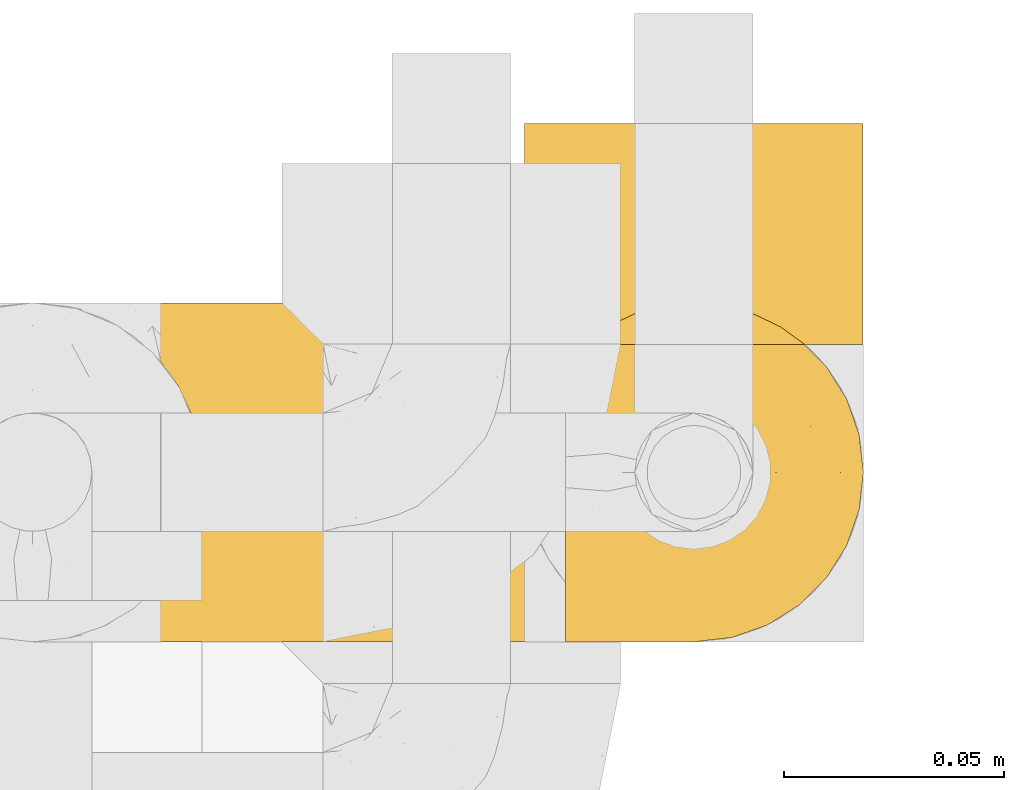
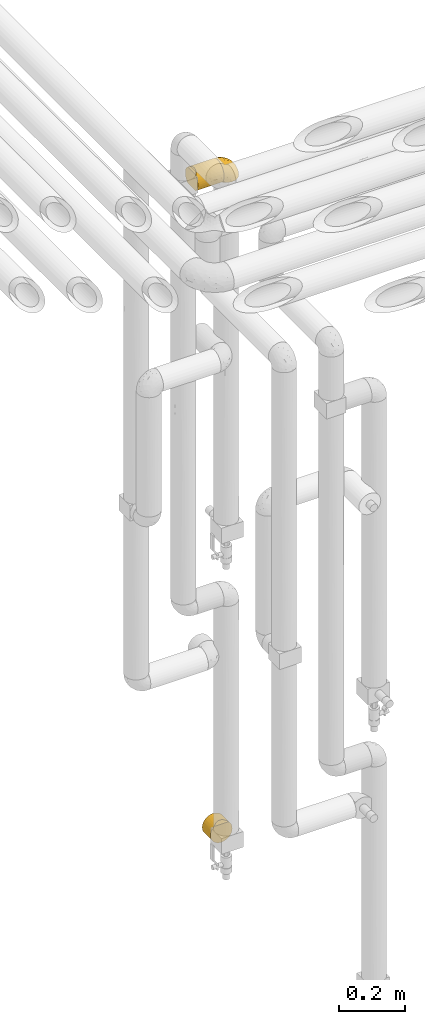
# One storey, part 293 of 827: 3 coverings.
"""IFC2X3 building model written with IfcOpenShell, lengths in millimetres."""

from ifc_helpers import new_model, entity, si_unit, converted_unit, derived_unit, direction, frame, origin, place, context, subcontext, project, spatial, faceted_brep, element, save


model = new_model("IFC2X3")

# Units and contexts
model_context = context("Model", 3, precision=0.01, world=origin(), true_north=direction((6.12303176911189e-17, 1.0)))
body_context = subcontext(model_context, "Body", "Model", "MODEL_VIEW")
ifc_project = project(units=[si_unit("LENGTHUNIT", "METRE", prefix="MILLI"), si_unit("AREAUNIT", "SQUARE_METRE"), si_unit("VOLUMEUNIT", "CUBIC_METRE"), converted_unit("PLANEANGLEUNIT", "DEGREE", entity("IfcRatioMeasure", 0.0174532925199433), si_unit("PLANEANGLEUNIT", "RADIAN"), dimensions=[0, 0, 0, 0, 0, 0, 0]), si_unit("MASSUNIT", "GRAM", prefix="KILO"), derived_unit("MASSDENSITYUNIT", [(si_unit("MASSUNIT", "GRAM", prefix="KILO"), 1), (si_unit("LENGTHUNIT", "METRE"), -3)]), derived_unit("MOMENTOFINERTIAUNIT", [(si_unit("LENGTHUNIT", "METRE"), 4)]), si_unit("TIMEUNIT", "SECOND"), si_unit("FREQUENCYUNIT", "HERTZ"), si_unit("THERMODYNAMICTEMPERATUREUNIT", "DEGREE_CELSIUS"), derived_unit("THERMALTRANSMITTANCEUNIT", [(si_unit("MASSUNIT", "GRAM", prefix="KILO"), 1), (si_unit("THERMODYNAMICTEMPERATUREUNIT", "KELVIN"), -1), (si_unit("TIMEUNIT", "SECOND"), -3)]), derived_unit("VOLUMETRICFLOWRATEUNIT", [(si_unit("LENGTHUNIT", "METRE"), 3), (si_unit("TIMEUNIT", "SECOND"), -1)]), derived_unit("MASSFLOWRATEUNIT", [(si_unit("MASSUNIT", "GRAM", prefix="KILO"), 1), (si_unit("TIMEUNIT", "SECOND"), -1)]), derived_unit("ROTATIONALFREQUENCYUNIT", [(si_unit("TIMEUNIT", "SECOND"), -1)]), si_unit("ELECTRICCURRENTUNIT", "AMPERE"), si_unit("ELECTRICVOLTAGEUNIT", "VOLT"), si_unit("POWERUNIT", "WATT"), si_unit("FORCEUNIT", "NEWTON", prefix="KILO"), si_unit("ILLUMINANCEUNIT", "LUX"), si_unit("LUMINOUSFLUXUNIT", "LUMEN"), si_unit("LUMINOUSINTENSITYUNIT", "CANDELA"), derived_unit("USERDEFINED", [(si_unit("MASSUNIT", "GRAM", prefix="KILO"), -1), (si_unit("LENGTHUNIT", "METRE"), -2), (si_unit("TIMEUNIT", "SECOND"), 3), (si_unit("LUMINOUSFLUXUNIT", "LUMEN"), 1)]), derived_unit("LINEARVELOCITYUNIT", [(si_unit("LENGTHUNIT", "METRE"), 1), (si_unit("TIMEUNIT", "SECOND"), -1)]), si_unit("PRESSUREUNIT", "PASCAL"), derived_unit("USERDEFINED", [(si_unit("LENGTHUNIT", "METRE"), -2), (si_unit("MASSUNIT", "GRAM", prefix="KILO"), 1), (si_unit("TIMEUNIT", "SECOND"), -2)]), derived_unit("LINEARFORCEUNIT", [(si_unit("MASSUNIT", "GRAM", prefix="KILO"), 1), (si_unit("LENGTHUNIT", "METRE"), 1), (si_unit("TIMEUNIT", "SECOND"), -2), (si_unit("LENGTHUNIT", "METRE"), -1)]), derived_unit("PLANARFORCEUNIT", [(si_unit("MASSUNIT", "GRAM", prefix="KILO"), 1), (si_unit("LENGTHUNIT", "METRE"), 1), (si_unit("TIMEUNIT", "SECOND"), -2), (si_unit("LENGTHUNIT", "METRE"), -2)])], contexts=[model_context])

# Site, building, storey
site_placement = place(None, origin())
site = spatial("IfcSite", under=ifc_project, at=site_placement, CompositionType="ELEMENT")
building_placement = place(site_placement, origin())
building = spatial("IfcBuilding", under=site, at=building_placement, CompositionType="ELEMENT")
storey_placement = place(building_placement, frame((0.0, 0.0, 28200.0)))
storey = spatial("IfcBuildingStorey", under=building, at=storey_placement, Name="08", CompositionType="ELEMENT", Elevation=28200.0)

# Coverings
covering_1_placement = place(storey_placement, frame((35020.29, 15782.05, 2810.0)))
element("IfcCovering", 1, at=covering_1_placement, inside=storey, Name=":ADSK_", ObjectType=":ADSK_", PredefinedType="INSULATION", context=body_context, shape_type="Brep", body=[
    faceted_brep([(1.6, 14.82, 11.0), (1.6, 9.24, 17.0), (1.6, 5.06, 24.05), (1.6, 2.47, 31.83), (1.6, 1.6, 40.0), (1.6, 2.47, 48.16), (1.6, 5.06, 55.94), (1.6, 9.24, 62.99), (1.6, 14.82, 69.0), (1.6, 65.17, 69.0), (1.6, 70.75, 62.99), (1.6, 74.93, 55.94), (1.6, 77.52, 48.16), (1.6, 78.4, 40.0), (1.6, 77.52, 31.83), (1.6, 74.93, 24.05), (1.6, 70.75, 17.0), (1.6, 65.17, 11.0), (93.5, 2.9, 49.93), (93.5, 1.6, 40.0), (93.5, 2.48, 31.79), (93.5, 5.09, 23.98), (93.5, 9.31, 16.91), (93.5, 14.94, 10.9), (93.5, 65.05, 10.9), (93.5, 70.68, 16.91), (93.5, 74.9, 23.98), (93.5, 77.51, 31.79), (93.5, 78.4, 40.0), (93.5, 77.09, 49.93), (93.5, 73.25, 59.2), (93.5, 67.15, 67.15), (93.5, 59.2, 73.25), (93.5, 49.93, 77.09), (93.5, 40.0, 78.4), (93.5, 30.06, 77.09), (93.5, 20.8, 73.25), (93.5, 12.84, 67.15), (93.5, 6.74, 59.2), (89.52, 59.51, 6.92), (5.61, 59.61, 6.98), (86.6, 53.36, 4.0), (84.8, 46.78, 2.2), (10.38, 46.82, 2.21), (8.57, 53.43, 4.02), (11.0, 40.0, 1.6), (84.2, 40.0, 1.6), (84.8, 33.21, 2.2), (86.6, 26.63, 4.0), (10.38, 33.17, 2.21), (89.52, 20.48, 6.92), (5.61, 20.38, 6.98), (8.57, 26.56, 4.02), (8.57, 26.56, 75.97), (10.38, 33.17, 77.78), (11.0, 40.0, 78.4), (5.61, 20.38, 73.01), (10.38, 46.82, 77.78), (8.57, 53.43, 75.97), (5.61, 59.61, 73.01)], [[[0, 1, 2, 3, 4, 5, 6, 7, 8, 9, 10, 11, 12, 13, 14, 15, 16, 17]], [[18, 19, 20, 21, 22, 23, 24, 25, 26, 27, 28, 29, 30, 31, 32, 33, 34, 35, 36, 37, 38]], [[28, 27, 14]], [[26, 25, 16]], [[27, 26, 15]], [[14, 13, 28]], [[26, 16, 15]], [[16, 25, 17]], [[14, 27, 15]], [[25, 24, 17]], [[24, 39, 40]], [[41, 42, 43]], [[39, 41, 44]], [[40, 39, 44]], [[42, 45, 43]], [[43, 44, 41]], [[45, 42, 46]], [[24, 40, 17]], [[47, 48, 49]], [[50, 23, 51]], [[48, 50, 52]], [[46, 47, 45]], [[45, 47, 49]], [[49, 48, 52]], [[50, 51, 52]], [[23, 0, 51]], [[1, 22, 21]], [[2, 21, 20]], [[3, 20, 19]], [[0, 22, 1]], [[2, 1, 21]], [[20, 3, 2]], [[19, 4, 3]], [[22, 0, 23]], [[5, 19, 18]], [[6, 18, 38]], [[7, 38, 37]], [[4, 19, 5]], [[5, 18, 6]], [[38, 7, 6]], [[37, 8, 7]], [[53, 36, 35]], [[35, 34, 54]], [[55, 54, 34]], [[56, 8, 36]], [[54, 53, 35]], [[56, 36, 53]], [[36, 8, 37]], [[57, 55, 34]], [[57, 34, 33]], [[58, 33, 32]], [[58, 57, 33]], [[9, 59, 32]], [[58, 32, 59]], [[32, 31, 9]], [[10, 31, 30]], [[11, 30, 29]], [[12, 29, 28]], [[10, 30, 11]], [[11, 29, 12]], [[28, 13, 12]], [[31, 10, 9]], [[17, 40, 44, 43, 45, 49, 52, 51, 0]], [[8, 56, 53, 54, 55, 57, 58, 59, 9]], [[46, 42, 41, 39, 24, 23, 50, 48, 47]]]),
])
covering_2_placement = place(storey_placement, frame((35112.19, 15782.0, 2819.3)))
element("IfcCovering", 2, at=covering_2_placement, inside=storey, Name=":ADSK_", ObjectType=":ADSK_", PredefinedType="INSULATION", context=body_context, shape_type="Brep", body=[
    faceted_brep([(47.38, 74.68, 1.6), (54.67, 70.1, 1.6), (60.76, 64.01, 1.6), (65.34, 56.72, 1.6), (68.18, 48.6, 1.6), (69.15, 40.05, 1.6), (68.18, 31.49, 1.6), (65.33, 23.36, 1.6), (60.75, 16.07, 1.6), (54.66, 9.98, 1.6), (47.37, 5.4, 1.6), (39.25, 2.56, 1.6), (30.7, 1.6, 1.6), (22.59, 2.46, 1.6), (14.86, 5.01, 1.6), (7.84, 9.13, 1.6), (1.85, 14.62, 1.6), (1.85, 16.82, 1.6), (1.85, 18.56, 1.6), (1.85, 20.52, 1.6), (1.85, 22.49, 1.6), (1.85, 24.46, 1.6), (1.85, 26.42, 1.6), (1.85, 28.39, 1.6), (1.85, 30.36, 1.6), (1.85, 32.55, 1.6), (1.85, 34.75, 1.6), (1.85, 36.94, 1.6), (1.85, 39.13, 1.6), (1.85, 41.33, 1.6), (1.85, 43.52, 1.6), (1.85, 45.72, 1.6), (1.85, 47.91, 1.6), (1.85, 50.11, 1.6), (1.85, 52.3, 1.6), (1.85, 54.49, 1.6), (1.85, 56.69, 1.6), (1.85, 58.88, 1.6), (1.85, 61.08, 1.6), (1.85, 63.27, 1.6), (1.85, 65.47, 1.6), (7.85, 70.97, 1.6), (14.88, 75.09, 1.6), (22.61, 77.64, 1.6), (30.7, 78.5, 1.6), (39.26, 77.53, 1.6), (1.6, 14.62, 1.85), (1.6, 9.12, 7.85), (1.6, 5.0, 14.87), (1.6, 2.46, 22.6), (1.6, 1.6, 30.7), (1.6, 2.91, 40.65), (1.6, 6.75, 49.92), (1.6, 12.86, 57.88), (1.6, 20.82, 63.99), (1.6, 30.09, 67.84), (1.6, 40.05, 69.15), (1.6, 50.0, 67.84), (1.6, 59.27, 63.99), (1.6, 67.23, 57.88), (1.6, 73.34, 49.92), (1.6, 77.19, 40.65), (1.6, 78.5, 30.7), (1.6, 77.63, 22.6), (1.6, 75.09, 14.87), (1.6, 70.97, 7.85), (1.6, 65.47, 1.85), (1.6, 63.27, 1.85), (1.6, 62.29, 1.85), (1.6, 60.7, 1.85), (1.6, 59.11, 1.85), (1.6, 57.52, 1.85), (1.6, 55.93, 1.85), (1.6, 54.34, 1.85), (1.6, 52.76, 1.85), (1.6, 51.17, 1.85), (1.6, 49.58, 1.85), (1.6, 47.99, 1.85), (1.6, 46.4, 1.85), (1.6, 44.81, 1.85), (1.6, 43.22, 1.85), (1.6, 41.63, 1.85), (1.6, 40.05, 1.85), (1.6, 38.46, 1.85), (1.6, 36.87, 1.85), (1.6, 35.28, 1.85), (1.6, 33.69, 1.85), (1.6, 32.1, 1.85), (1.6, 30.51, 1.85), (1.6, 28.92, 1.85), (1.6, 27.33, 1.85), (1.6, 25.37, 1.85), (1.6, 23.4, 1.85), (1.6, 21.21, 1.85), (1.6, 19.01, 1.85), (1.6, 16.82, 1.85), (1.78, 42.32, 1.77), (1.77, 44.02, 1.78), (1.78, 47.13, 1.77), (1.77, 48.74, 1.77), (1.79, 23.57, 1.76), (1.78, 25.13, 1.77), (1.76, 61.34, 1.79), (1.77, 22.02, 1.78), (1.77, 29.72, 1.78), (1.76, 56.73, 1.78), (1.77, 55.14, 1.78), (1.77, 37.66, 1.78), (1.8, 64.12, 1.74), (1.76, 28.13, 1.78), (1.77, 26.62, 1.78), (1.78, 31.46, 1.77), (1.77, 16.16, 1.78), (1.77, 39.16, 1.78), (1.76, 50.37, 1.78), (1.77, 17.69, 1.77), (1.78, 19.17, 1.77), (1.77, 62.78, 1.77), (1.77, 58.35, 1.78), (1.77, 45.53, 1.78), (1.78, 59.91, 1.77), (1.77, 65.47, 1.77), (1.8, 65.47, 1.72), (1.82, 65.47, 1.66), (1.77, 14.62, 1.77), (1.72, 14.62, 1.8), (1.66, 14.62, 1.82), (1.76, 20.59, 1.79), (1.77, 32.99, 1.78), (1.76, 34.48, 1.79), (1.77, 51.91, 1.78), (1.66, 65.47, 1.82), (1.72, 65.47, 1.8), (1.78, 53.48, 1.76), (1.82, 14.62, 1.66), (1.8, 14.62, 1.72), (1.77, 40.77, 1.78), (1.78, 35.97, 1.77), (3.72, 7.84, 9.41), (7.41, 3.53, 17.65), (6.13, 8.32, 7.41), (21.47, 1.6, 21.47), (19.34, 2.19, 15.21), (26.8, 1.6, 16.15), (8.87, 1.6, 28.75), (9.2, 4.57, 13.67), (12.79, 3.96, 12.79), (14.62, 2.28, 19.18), (7.34, 1.6, 29.16), (5.33, 7.69, 9.04), (17.64, 3.53, 7.41), (7.7, 8.32, 5.74), (9.41, 7.84, 3.72), (28.75, 1.6, 8.87), (16.15, 1.6, 26.8), (14.14, 4.34, 9.53), (29.16, 1.6, 7.34), (57.02, 29.63, 37.63), (64.92, 27.34, 17.92), (64.0, 40.05, 27.45), (11.92, 2.39, 37.01), (19.16, 2.43, 34.22), (28.65, 9.07, 45.87), (24.62, 16.64, 56.57), (15.19, 9.54, 52.31), (18.36, 4.52, 42.07), (9.2, 4.52, 44.74), (46.98, 7.49, 21.49), (50.24, 7.49, 11.02), (56.1, 12.85, 15.64), (28.97, 2.35, 26.02), (54.46, 22.66, 36.59), (21.34, 32.9, 65.49), (18.4, 25.33, 63.99), (66.44, 40.05, 15.2), (12.07, 16.64, 60.27), (45.49, 19.99, 45.25), (50.57, 16.37, 35.21), (36.04, 3.26, 22.52), (42.07, 3.75, 12.03), (62.12, 19.58, 13.32), (37.37, 7.5, 35.9), (29.39, 4.04, 33.87), (53.59, 13.94, 25.73), (58.06, 19.58, 26.34), (49.27, 28.21, 46.78), (29.63, 24.75, 59.54), (33.21, 31.42, 60.18), (40.1, 26.2, 53.93), (44.08, 33.36, 53.36), (49.36, 40.05, 49.36), (56.68, 40.05, 38.4), (15.2, 40.05, 66.44), (35.57, 16.14, 50.09), (41.7, 12.85, 41.08), (46.4, 10.47, 31.14), (41.41, 6.49, 28.19), (27.45, 40.05, 64.0), (38.4, 40.05, 56.68), (12.99, 75.57, 43.9), (21.33, 47.37, 65.46), (42.89, 52.91, 52.22), (57.04, 50.46, 37.61), (56.11, 67.23, 15.64), (62.13, 60.5, 13.31), (21.89, 70.55, 50.02), (16.62, 63.45, 59.28), (32.9, 62.61, 53.05), (46.99, 72.6, 21.48), (50.25, 72.6, 11.01), (42.08, 76.34, 12.03), (49.91, 59.34, 41.02), (15.6, 77.76, 35.39), (16.15, 78.5, 26.8), (8.87, 78.5, 28.75), (29.16, 78.5, 7.34), (13.16, 53.16, 65.81), (10.83, 70.55, 53.28), (33.8, 48.88, 59.8), (25.02, 54.76, 61.82), (64.92, 52.74, 17.91), (32.83, 71.93, 41.4), (20.56, 75.79, 40.48), (58.07, 60.5, 26.34), (21.46, 77.86, 31.68), (28.1, 77.64, 27.68), (26.8, 78.5, 16.15), (21.47, 78.5, 21.47), (51.29, 67.23, 28.05), (36.04, 76.82, 22.54), (28.75, 78.5, 8.87), (8.45, 77.8, 37.3), (41.73, 67.23, 41.07), (39.27, 73.2, 32.24), (33.56, 67.66, 47.4), (27.29, 75.99, 35.77), (7.41, 76.57, 17.65), (3.51, 73.21, 11.06), (4.68, 71.93, 8.55), (5.52, 71.07, 6.63), (8.75, 75.09, 12.77), (12.79, 76.13, 12.79), (17.65, 76.57, 7.41), (13.9, 77.69, 18.97), (9.42, 72.26, 3.72), (7.68, 71.77, 5.76), (19.33, 77.9, 15.21), (14.13, 75.75, 9.52)], [[[0, 1, 2, 3, 4, 5, 6, 7, 8, 9, 10, 11, 12, 13, 14, 15, 16, 17, 18, 19, 20, 21, 22, 23, 24, 25, 26, 27, 28, 29, 30, 31, 32, 33, 34, 35, 36, 37, 38, 39, 40, 41, 42, 43, 44, 45]], [[46, 47, 48, 49, 50, 51, 52, 53, 54, 55, 56, 57, 58, 59, 60, 61, 62, 63, 64, 65, 66, 67, 68, 69, 70, 71, 72, 73, 74, 75, 76, 77, 78, 79, 80, 81, 82, 83, 84, 85, 86, 87, 88, 89, 90, 91, 92, 93, 94, 95]], [[96, 97, 30]], [[98, 77, 99]], [[100, 101, 21]], [[69, 68, 102]], [[20, 19, 103]], [[24, 23, 104]], [[20, 103, 100]], [[72, 105, 106]], [[84, 83, 107]], [[89, 88, 104]], [[108, 67, 66]], [[109, 110, 90]], [[111, 25, 24]], [[112, 17, 16]], [[82, 113, 83]], [[109, 23, 22]], [[114, 76, 75]], [[105, 36, 106]], [[104, 111, 24]], [[18, 115, 116]], [[97, 96, 80]], [[67, 108, 117]], [[105, 71, 118]], [[31, 97, 119]], [[102, 120, 69]], [[108, 121, 122, 123, 40]], [[112, 95, 115]], [[17, 115, 18]], [[94, 116, 115]], [[117, 68, 67]], [[38, 117, 39]], [[112, 124, 125, 126, 46]], [[17, 112, 115]], [[70, 120, 118]], [[39, 117, 108]], [[120, 38, 37]], [[120, 37, 118]], [[120, 70, 69]], [[116, 94, 127]], [[128, 86, 129]], [[117, 38, 102]], [[74, 130, 75]], [[99, 33, 32]], [[115, 95, 94]], [[39, 108, 40]], [[108, 66, 131, 132, 121]], [[105, 72, 71]], [[118, 37, 36]], [[71, 70, 118]], [[35, 106, 36]], [[36, 105, 118]], [[35, 133, 106]], [[74, 73, 133]], [[106, 133, 73]], [[99, 114, 33]], [[133, 35, 34]], [[73, 72, 106]], [[95, 112, 46]], [[112, 16, 134, 135, 124]], [[130, 114, 75]], [[99, 76, 114]], [[114, 130, 33]], [[34, 33, 130]], [[78, 77, 98]], [[98, 119, 78]], [[130, 133, 34]], [[133, 130, 74]], [[79, 97, 80]], [[98, 99, 32]], [[98, 32, 31]], [[77, 76, 99]], [[97, 79, 119]], [[136, 96, 29]], [[30, 97, 31]], [[136, 29, 28]], [[81, 80, 96]], [[29, 96, 30]], [[31, 119, 98]], [[119, 79, 78]], [[96, 136, 81]], [[82, 81, 136]], [[113, 107, 83]], [[84, 107, 137]], [[107, 27, 137]], [[113, 28, 107]], [[27, 107, 28]], [[85, 84, 137]], [[137, 27, 26]], [[113, 136, 28]], [[136, 113, 82]], [[109, 89, 104]], [[86, 85, 129]], [[89, 109, 90]], [[111, 87, 128]], [[26, 129, 137]], [[88, 111, 104]], [[25, 111, 128]], [[22, 110, 109]], [[23, 109, 104]], [[110, 91, 90]], [[100, 92, 101]], [[110, 22, 101]], [[91, 110, 101]], [[116, 19, 18]], [[111, 88, 87]], [[127, 103, 19]], [[25, 128, 26]], [[86, 128, 87]], [[128, 129, 26]], [[137, 129, 85]], [[120, 102, 38]], [[117, 102, 68]], [[91, 101, 92]], [[21, 101, 22]], [[93, 92, 103]], [[100, 21, 20]], [[100, 103, 92]], [[127, 93, 103]], [[93, 127, 94]], [[116, 127, 19]], [[126, 138, 47]], [[48, 138, 139]], [[140, 125, 124]], [[141, 142, 143]], [[144, 49, 139]], [[145, 140, 146]], [[48, 139, 49]], [[139, 145, 147]], [[49, 144, 148, 50]], [[126, 125, 149]], [[14, 13, 150]], [[151, 146, 140]], [[149, 140, 145]], [[152, 151, 135]], [[152, 14, 150]], [[16, 15, 134]], [[13, 153, 150]], [[124, 151, 140]], [[141, 147, 142]], [[14, 152, 15]], [[15, 152, 134]], [[47, 46, 126]], [[139, 154, 144]], [[138, 48, 47]], [[125, 140, 149]], [[135, 134, 152]], [[146, 155, 142]], [[145, 146, 147]], [[149, 139, 138]], [[147, 141, 154]], [[147, 146, 142]], [[139, 147, 154]], [[139, 149, 145]], [[149, 138, 126]], [[155, 146, 151]], [[150, 143, 142]], [[152, 155, 151]], [[150, 142, 155]], [[13, 12, 156, 153]], [[153, 143, 150]], [[152, 150, 155]], [[151, 124, 135]], [[157, 158, 159]], [[160, 154, 161]], [[162, 163, 164]], [[165, 166, 160]], [[167, 168, 169]], [[141, 170, 161]], [[156, 12, 11]], [[158, 157, 171]], [[172, 55, 173]], [[158, 6, 174]], [[175, 54, 53]], [[52, 166, 164]], [[52, 164, 53]], [[54, 175, 173]], [[166, 52, 51]], [[176, 177, 171]], [[178, 143, 179]], [[156, 11, 179]], [[8, 7, 180]], [[169, 9, 8]], [[179, 143, 153, 156]], [[179, 11, 10]], [[168, 179, 10]], [[181, 162, 182]], [[179, 167, 178]], [[183, 184, 177]], [[183, 169, 184]], [[176, 171, 185]], [[172, 186, 187]], [[158, 7, 6]], [[159, 158, 174]], [[184, 180, 158]], [[54, 173, 55]], [[180, 169, 8]], [[188, 189, 187]], [[9, 168, 10]], [[186, 188, 187]], [[190, 157, 159, 191]], [[55, 172, 192]], [[176, 193, 194]], [[161, 170, 182]], [[162, 164, 165]], [[175, 164, 163]], [[51, 50, 148]], [[167, 195, 196]], [[178, 182, 170]], [[6, 5, 174]], [[158, 180, 7]], [[169, 180, 184]], [[169, 168, 9]], [[179, 168, 167]], [[182, 162, 165]], [[162, 194, 193]], [[161, 165, 160]], [[195, 181, 196]], [[192, 172, 197]], [[192, 56, 55]], [[189, 190, 198]], [[198, 197, 187]], [[172, 187, 197]], [[185, 189, 188]], [[198, 187, 189]], [[186, 172, 173]], [[173, 163, 186]], [[193, 186, 163]], [[176, 185, 188]], [[185, 157, 190]], [[188, 186, 193]], [[177, 176, 194]], [[188, 193, 176]], [[162, 193, 163]], [[195, 177, 194]], [[171, 177, 184]], [[181, 195, 194]], [[183, 167, 169]], [[162, 181, 194]], [[196, 182, 178]], [[158, 171, 184]], [[171, 157, 185]], [[177, 195, 183]], [[167, 183, 195]], [[182, 196, 181]], [[178, 170, 143]], [[178, 167, 196]], [[164, 175, 53]], [[173, 175, 163]], [[160, 51, 148]], [[164, 166, 165]], [[51, 160, 166]], [[160, 148, 144, 154]], [[141, 161, 154]], [[182, 165, 161]], [[190, 189, 185]], [[143, 170, 141]], [[60, 199, 61]], [[197, 200, 192]], [[201, 190, 202]], [[200, 57, 192]], [[203, 204, 2]], [[205, 206, 207]], [[208, 209, 210]], [[211, 207, 201]], [[212, 213, 214]], [[45, 215, 210]], [[216, 206, 58]], [[45, 44, 215]], [[59, 217, 60]], [[60, 217, 199]], [[0, 45, 210]], [[218, 201, 219]], [[202, 159, 220]], [[205, 221, 222]], [[223, 204, 203]], [[1, 203, 2]], [[57, 200, 216]], [[220, 3, 204]], [[220, 174, 4]], [[1, 0, 209]], [[212, 224, 213]], [[225, 226, 227]], [[228, 223, 203]], [[208, 210, 229]], [[210, 226, 229]], [[3, 220, 4]], [[58, 206, 59]], [[209, 203, 1]], [[202, 220, 223]], [[228, 203, 208]], [[202, 211, 201]], [[3, 2, 204]], [[202, 190, 191, 159]], [[210, 215, 230, 226]], [[199, 212, 231]], [[232, 233, 221]], [[233, 208, 229]], [[207, 206, 219]], [[217, 206, 205]], [[227, 224, 225]], [[233, 232, 228]], [[201, 207, 219]], [[234, 232, 221]], [[218, 219, 200]], [[202, 223, 211]], [[174, 220, 159]], [[174, 5, 4]], [[61, 231, 62]], [[220, 204, 223]], [[210, 209, 0]], [[203, 209, 208]], [[225, 233, 229]], [[224, 227, 213]], [[221, 233, 235]], [[57, 56, 192]], [[198, 218, 197]], [[200, 219, 216]], [[201, 198, 190]], [[197, 218, 200]], [[198, 201, 218]], [[206, 216, 219]], [[58, 57, 216]], [[231, 212, 214]], [[222, 212, 199]], [[228, 211, 223]], [[207, 211, 232]], [[62, 231, 214]], [[199, 231, 61]], [[233, 228, 208]], [[211, 228, 232]], [[222, 221, 235]], [[234, 205, 207]], [[206, 217, 59]], [[199, 217, 205]], [[205, 222, 199]], [[224, 222, 235]], [[222, 224, 212]], [[224, 235, 225]], [[233, 225, 235]], [[226, 225, 229]], [[205, 234, 221]], [[207, 232, 234]], [[63, 214, 236]], [[214, 213, 236]], [[214, 63, 62]], [[237, 236, 238]], [[238, 132, 131]], [[236, 237, 64]], [[239, 240, 241]], [[63, 236, 64]], [[131, 66, 65]], [[237, 131, 65]], [[242, 230, 43]], [[237, 65, 64]], [[239, 121, 132]], [[42, 242, 43]], [[241, 240, 243]], [[41, 123, 244]], [[43, 230, 215, 44]], [[244, 122, 245]], [[227, 246, 243]], [[241, 247, 245]], [[121, 239, 245]], [[41, 40, 123]], [[132, 238, 239]], [[244, 42, 41]], [[131, 237, 238]], [[240, 239, 238]], [[245, 239, 241]], [[247, 241, 246]], [[247, 244, 245]], [[238, 236, 240]], [[243, 236, 213]], [[236, 243, 240]], [[227, 226, 246]], [[243, 213, 227]], [[242, 246, 226]], [[243, 246, 241]], [[246, 242, 247]], [[244, 247, 242]], [[242, 226, 230]], [[42, 244, 242]], [[122, 244, 123]], [[122, 121, 245]]]),
])
covering_3_placement = place(storey_placement, frame((35102.89, 15849.45, 332.0)))
element("IfcCovering", 3, at=covering_3_placement, inside=storey, Name=":ADSK_", ObjectType=":ADSK_", PredefinedType="INSULATION", context=body_context, shape_type="Brep", body=[
    faceted_brep([(20.8, 1.6, 6.74), (30.06, 1.6, 2.9), (40.0, 1.6, 1.6), (49.93, 1.6, 2.9), (59.2, 1.6, 6.74), (67.15, 1.6, 12.84), (73.25, 1.6, 20.8), (77.09, 1.6, 30.06), (78.4, 1.6, 40.0), (77.52, 1.6, 48.16), (74.93, 1.6, 55.94), (70.75, 1.6, 62.99), (65.17, 1.6, 69.0), (14.82, 1.6, 69.0), (9.24, 1.6, 62.99), (5.06, 1.6, 55.94), (2.47, 1.6, 48.16), (1.6, 1.6, 40.0), (2.9, 1.6, 30.06), (6.74, 1.6, 20.8), (12.84, 1.6, 12.84), (20.8, 51.7, 6.74), (12.84, 51.7, 12.84), (6.74, 51.7, 20.8), (2.9, 51.7, 30.06), (1.6, 51.7, 40.0), (2.9, 51.7, 49.93), (6.74, 51.7, 59.2), (12.84, 51.7, 67.15), (20.8, 51.7, 73.25), (30.06, 51.7, 77.09), (40.0, 51.7, 78.4), (49.93, 51.7, 77.09), (59.2, 51.7, 73.25), (67.15, 51.7, 67.15), (73.25, 51.7, 59.2), (77.09, 51.7, 49.93), (78.4, 51.7, 40.0), (77.09, 51.7, 30.06), (73.25, 51.7, 20.8), (67.15, 51.7, 12.84), (59.2, 51.7, 6.74), (49.93, 51.7, 2.9), (40.0, 51.7, 1.6), (30.06, 51.7, 2.9), (53.43, 8.57, 75.97), (46.82, 10.38, 77.78), (40.0, 11.0, 78.4), (59.61, 5.61, 73.01), (33.17, 10.38, 77.78), (26.56, 8.57, 75.97), (20.38, 5.61, 73.01)], [[[0, 1, 2, 3, 4, 5, 6, 7, 8, 9, 10, 11, 12, 13, 14, 15, 16, 17, 18, 19, 20]], [[21, 22, 23, 24, 25, 26, 27, 28, 29, 30, 31, 32, 33, 34, 35, 36, 37, 38, 39, 40, 41, 42, 43, 44]], [[17, 25, 24, 18]], [[18, 24, 23, 19]], [[22, 20, 19, 23]], [[1, 0, 21, 44]], [[2, 1, 44, 43]], [[22, 21, 0, 20]], [[42, 41, 4, 3]], [[43, 42, 3, 2]], [[41, 40, 5, 4]], [[7, 6, 39, 38]], [[8, 7, 38, 37]], [[40, 39, 6, 5]], [[9, 37, 36]], [[10, 36, 35]], [[11, 35, 34]], [[8, 37, 9]], [[9, 36, 10]], [[35, 11, 10]], [[34, 12, 11]], [[45, 33, 32]], [[32, 31, 46]], [[47, 46, 31]], [[48, 12, 33]], [[46, 45, 32]], [[48, 33, 45]], [[33, 12, 34]], [[49, 47, 31]], [[49, 31, 30]], [[50, 30, 29]], [[50, 49, 30]], [[13, 51, 29]], [[50, 29, 51]], [[29, 28, 13]], [[14, 28, 27]], [[15, 27, 26]], [[16, 26, 25]], [[14, 27, 15]], [[15, 26, 16]], [[25, 17, 16]], [[28, 14, 13]], [[45, 46, 47, 49, 50, 51, 13, 12, 48]]]),
])

save(model, "model.ifc")
